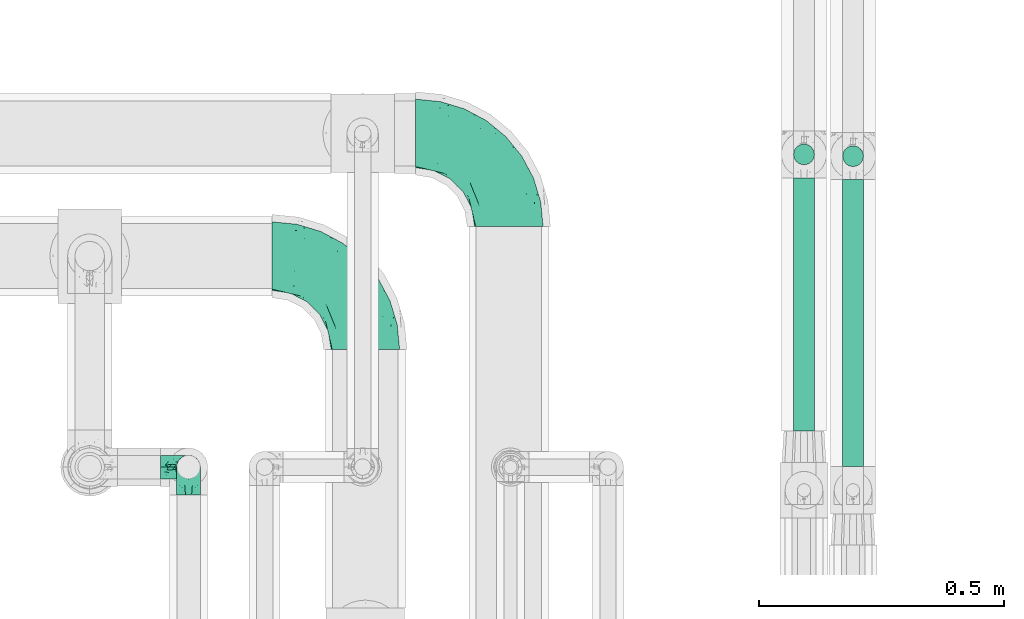
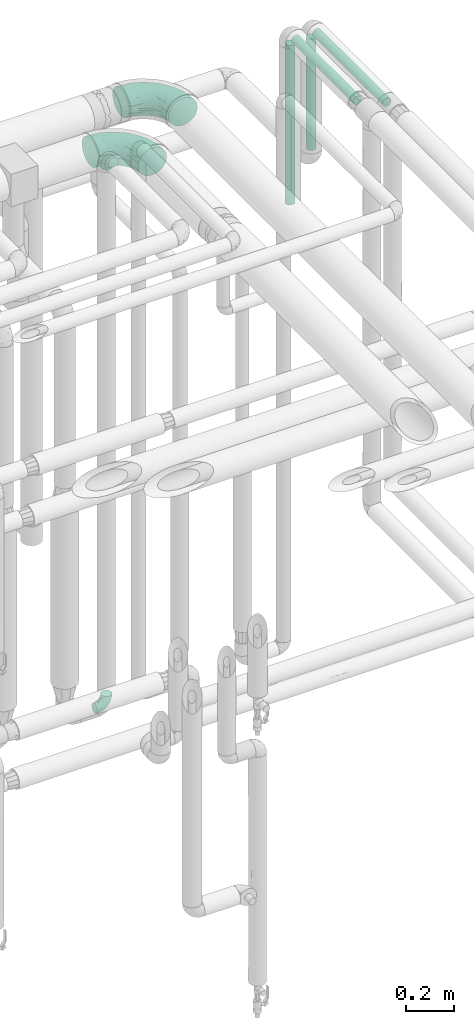
# One storey, part 726 of 827: 4 flow fittings, 4 flow segments.
"""IFC2X3 building model written with IfcOpenShell, lengths in millimetres."""

from ifc_helpers import new_model, entity, si_unit, converted_unit, derived_unit, direction, frame, origin, origin_2d_with_axis, place, context, subcontext, project, spatial, circle, extrude, faceted_brep, source, transform, mapped, material, type_object, type_shapes, element, save


model = new_model("IFC2X3")

# Units and contexts
model_context = context("Model", 3, precision=0.01, world=origin(), true_north=direction((6.12303176911189e-17, 1.0)))
body_context = subcontext(model_context, "Body", "Model", "MODEL_VIEW")
ifc_project = project(units=[si_unit("LENGTHUNIT", "METRE", prefix="MILLI"), si_unit("AREAUNIT", "SQUARE_METRE"), si_unit("VOLUMEUNIT", "CUBIC_METRE"), converted_unit("PLANEANGLEUNIT", "DEGREE", entity("IfcRatioMeasure", 0.0174532925199433), si_unit("PLANEANGLEUNIT", "RADIAN"), dimensions=[0, 0, 0, 0, 0, 0, 0]), si_unit("MASSUNIT", "GRAM", prefix="KILO"), derived_unit("MASSDENSITYUNIT", [(si_unit("MASSUNIT", "GRAM", prefix="KILO"), 1), (si_unit("LENGTHUNIT", "METRE"), -3)]), derived_unit("MOMENTOFINERTIAUNIT", [(si_unit("LENGTHUNIT", "METRE"), 4)]), si_unit("TIMEUNIT", "SECOND"), si_unit("FREQUENCYUNIT", "HERTZ"), si_unit("THERMODYNAMICTEMPERATUREUNIT", "DEGREE_CELSIUS"), derived_unit("THERMALTRANSMITTANCEUNIT", [(si_unit("MASSUNIT", "GRAM", prefix="KILO"), 1), (si_unit("THERMODYNAMICTEMPERATUREUNIT", "KELVIN"), -1), (si_unit("TIMEUNIT", "SECOND"), -3)]), derived_unit("VOLUMETRICFLOWRATEUNIT", [(si_unit("LENGTHUNIT", "METRE"), 3), (si_unit("TIMEUNIT", "SECOND"), -1)]), derived_unit("MASSFLOWRATEUNIT", [(si_unit("MASSUNIT", "GRAM", prefix="KILO"), 1), (si_unit("TIMEUNIT", "SECOND"), -1)]), derived_unit("ROTATIONALFREQUENCYUNIT", [(si_unit("TIMEUNIT", "SECOND"), -1)]), si_unit("ELECTRICCURRENTUNIT", "AMPERE"), si_unit("ELECTRICVOLTAGEUNIT", "VOLT"), si_unit("POWERUNIT", "WATT"), si_unit("FORCEUNIT", "NEWTON", prefix="KILO"), si_unit("ILLUMINANCEUNIT", "LUX"), si_unit("LUMINOUSFLUXUNIT", "LUMEN"), si_unit("LUMINOUSINTENSITYUNIT", "CANDELA"), derived_unit("USERDEFINED", [(si_unit("MASSUNIT", "GRAM", prefix="KILO"), -1), (si_unit("LENGTHUNIT", "METRE"), -2), (si_unit("TIMEUNIT", "SECOND"), 3), (si_unit("LUMINOUSFLUXUNIT", "LUMEN"), 1)]), derived_unit("LINEARVELOCITYUNIT", [(si_unit("LENGTHUNIT", "METRE"), 1), (si_unit("TIMEUNIT", "SECOND"), -1)]), si_unit("PRESSUREUNIT", "PASCAL"), derived_unit("USERDEFINED", [(si_unit("LENGTHUNIT", "METRE"), -2), (si_unit("MASSUNIT", "GRAM", prefix="KILO"), 1), (si_unit("TIMEUNIT", "SECOND"), -2)]), derived_unit("LINEARFORCEUNIT", [(si_unit("MASSUNIT", "GRAM", prefix="KILO"), 1), (si_unit("LENGTHUNIT", "METRE"), 1), (si_unit("TIMEUNIT", "SECOND"), -2), (si_unit("LENGTHUNIT", "METRE"), -1)]), derived_unit("PLANARFORCEUNIT", [(si_unit("MASSUNIT", "GRAM", prefix="KILO"), 1), (si_unit("LENGTHUNIT", "METRE"), 1), (si_unit("TIMEUNIT", "SECOND"), -2), (si_unit("LENGTHUNIT", "METRE"), -2)])], contexts=[model_context])

# Site, building, storey
site_placement = place(None, origin())
site = spatial("IfcSite", under=ifc_project, at=site_placement, CompositionType="ELEMENT")
building_placement = place(site_placement, origin())
building = spatial("IfcBuilding", under=site, at=building_placement, CompositionType="ELEMENT")
storey_placement = place(building_placement, frame((0.0, 0.0, 28200.0)))
storey = spatial("IfcBuildingStorey", under=building, at=storey_placement, Name="08", CompositionType="ELEMENT", Elevation=28200.0)

# Flow segments
pipe_segment_type = type_object("IfcPipeSegmentType", PredefinedType="NOTDEFINED")
flow_segment_1_placement = place(storey_placement, frame((61129.89, 17500.83, 2977.0)))
element("IfcFlowSegment", 1, at=flow_segment_1_placement, inside=storey, type_object=pipe_segment_type, context=body_context, shape_type="SweptSolid", body=[
    extrude(circle(Radius=21.15, at=origin_2d_with_axis()), frame((22.75, 0.0, 22.75), z_axis=(0.0, 1.0, 0.0), x_axis=(1.0, 0.0, 0.0)), (0.0, 0.0, 1.0), 585.000000000008),
])
flow_segment_2_placement = place(storey_placement, frame((61029.89, 17573.83, 2977.0)))
element("IfcFlowSegment", 2, at=flow_segment_2_placement, inside=storey, type_object=pipe_segment_type, context=body_context, shape_type="SweptSolid", body=[
    extrude(circle(Radius=21.15, at=origin_2d_with_axis()), frame((22.75, 0.0, 22.75), z_axis=(0.0, 1.0, 0.0), x_axis=(1.0, 0.0, 0.0)), (0.0, 0.0, 1.0), 515.500000000028),
])
flow_segment_3_placement = place(storey_placement, frame((61029.89, 18114.59, 2137.37)))
element("IfcFlowSegment", 3, at=flow_segment_3_placement, inside=storey, type_object=pipe_segment_type, context=body_context, shape_type="SweptSolid", body=[
    extrude(circle(Radius=21.15, at=origin_2d_with_axis()), frame((22.75, 22.75, 0.0)), (0.0, 0.0, 1.0), 814.370023810611),
])
flow_segment_4_placement = place(storey_placement, frame((61129.89, 18111.09, 2382.74)))
element("IfcFlowSegment", 4, at=flow_segment_4_placement, inside=storey, type_object=pipe_segment_type, context=body_context, shape_type="SweptSolid", body=[
    extrude(circle(Radius=21.15, at=origin_2d_with_axis()), frame((22.75, 22.75, 0.0)), (0.0, 0.0, 1.0), 569.000000000031),
])

# Flow fittings
ifc_material = material()
pipe_fitting_type_1 = type_object("IfcPipeFittingType", Name="ADSK_1", PredefinedType="NOTDEFINED", material=ifc_material)
shared_shape_1 = source(origin(), body_context, "Body", "Brep", [
    faceted_brep([(-57.0, 12.07, -20.91), (-57.0, 6.25, -23.33), (-57.0, 0.0, -24.15), (-57.0, -6.25, -23.33), (-57.0, -12.08, -20.91), (-57.0, -17.08, -17.08), (-57.0, -20.91, -12.08), (-57.0, -23.33, -6.25), (-57.0, -24.15, 0.0), (-57.0, -23.33, 6.25), (-57.0, -20.91, 12.07), (-57.0, -17.08, 17.08), (-57.0, -12.08, 20.91), (-57.0, -6.25, 23.33), (-57.0, 0.0, 24.15), (-57.0, 6.25, 23.33), (-57.0, 12.07, 20.91), (-57.0, 17.08, 17.08), (-57.0, 20.91, 12.07), (-57.0, 23.33, 6.25), (-57.0, 24.15, 0.0), (-57.0, 23.33, -6.25), (-57.0, 20.91, -12.08), (-57.0, 17.08, -17.08), (0.0, 57.0, -24.15), (-6.25, 57.0, -23.33), (-12.07, 57.0, -20.91), (-17.08, 57.0, -17.08), (-20.91, 57.0, -12.08), (-23.33, 57.0, -6.25), (-24.15, 57.0, 0.0), (-23.33, 57.0, 6.25), (-20.91, 57.0, 12.07), (-17.08, 57.0, 17.08), (-12.07, 57.0, 20.91), (-6.25, 57.0, 23.33), (0.0, 57.0, 24.15), (6.25, 57.0, 23.33), (12.08, 57.0, 20.91), (17.08, 57.0, 17.08), (20.91, 57.0, 12.07), (23.33, 57.0, 6.25), (24.15, 57.0, 0.0), (23.33, 57.0, -6.25), (20.91, 57.0, -12.08), (17.08, 57.0, -17.08), (12.08, 57.0, -20.91), (6.25, 57.0, -23.33), (14.9, 21.14, 6.17), (13.61, 24.64, 12.48), (6.23, 8.95, 8.98), (-41.47, -21.06, 0.0), (-41.92, -18.38, 13.72), (-24.64, -13.61, 12.48), (-37.37, -13.24, 18.15), (-6.8, -4.93, 8.18), (-21.76, -15.19, 6.22), (-12.78, -9.18, 0.0), (-37.73, -20.51, 7.75), (-7.38, 7.38, 20.24), (-23.37, -4.26, 20.42), (-11.9, -3.19, 15.86), (-42.14, -8.7, 21.82), (13.24, 37.37, 18.15), (9.33, 23.53, 16.85), (4.26, 23.37, 20.42), (2.77, 10.92, 15.55), (-29.46, 0.91, 23.52), (-44.13, 20.56, 15.69), (-39.25, 26.33, 10.88), (-49.02, 22.92, 9.96), (-34.58, 23.87, 17.15), (-15.8, 6.8, 22.81), (-8.67, 20.47, 23.88), (-18.12, 12.9, 24.08), (-48.29, 14.92, 19.65), (-44.06, -2.85, 23.78), (-9.23, 48.95, 22.58), (-3.78, 42.74, 24.07), (-40.34, 4.26, 24.09), (-44.02, 26.14, 5.46), (-44.04, 9.88, 22.74), (-4.95, 16.87, 22.52), (-2.75, 1.43, 12.5), (-25.48, 40.98, 10.71), (20.51, 37.73, 7.75), (18.38, 41.92, 13.72), (8.7, 42.14, 21.82), (-25.95, -17.97, 0.0), (2.85, 44.06, 23.78), (21.06, 41.47, 0.0), (17.97, 25.95, 0.0), (-24.04, -9.27, 17.13), (-33.26, 33.26, 5.86), (-28.55, 40.57, 0.0), (-40.57, 28.55, 0.0), (-25.29, 47.19, 4.06), (-27.01, 31.1, 16.77), (-15.7, 43.95, 19.9), (-20.27, 45.22, 15.61), (-30.53, 31.98, 12.64), (-11.28, 38.33, 22.92), (-9.97, 27.88, 24.09), (-20.15, 30.26, 21.25), (-31.25, 11.75, 23.64), (-28.75, 7.23, 24.15), (-29.53, 18.06, 22.27), (-28.44, 24.21, 20.02), (-37.55, 17.7, 20.26), (-15.88, 29.25, 22.99), (-20.82, 20.82, 23.44), (-0.91, 29.46, 23.52), (-13.5, -7.67, 12.04), (1.49, 1.56, 5.16), (8.86, 10.35, 4.59), (0.38, -0.38, 0.0), (9.18, 12.78, 0.0), (-37.37, -13.24, -18.15), (8.86, 10.35, -4.59), (-45.22, 20.27, -15.61), (-43.95, 15.7, -19.9), (-38.33, 11.28, -22.92), (-48.95, 9.23, -22.58), (-47.19, 25.29, -4.06), (-33.26, 33.26, -5.86), (18.38, 41.92, -13.72), (-30.26, 20.15, -21.25), (2.85, 44.06, -23.78), (-4.26, 40.34, -24.09), (-40.98, 25.48, -10.71), (-41.92, -18.38, -13.72), (9.25, 23.5, -16.92), (4.26, 23.37, -20.42), (13.24, 37.37, -18.15), (-37.73, -20.51, -7.75), (-11.75, 31.25, -23.64), (-7.23, 28.75, -24.15), (-12.9, 18.12, -24.08), (8.7, 42.14, -21.82), (-44.06, -2.85, -23.78), (-6.8, 15.8, -22.81), (-20.47, 8.67, -23.88), (-24.64, -13.61, -12.48), (-42.74, 3.78, -24.07), (-18.06, 29.53, -22.27), (-24.21, 28.44, -20.02), (-27.88, 9.97, -24.09), (-31.1, 27.01, -16.77), (-26.14, 44.02, -5.46), (14.9, 21.14, -6.17), (20.51, 37.73, -7.75), (-9.88, 44.04, -22.74), (-20.56, 44.13, -15.69), (-21.76, -15.19, -6.22), (-13.5, -7.67, -12.04), (-24.14, -9.76, -16.74), (-11.9, -3.19, -15.86), (-14.92, 48.29, -19.65), (-23.37, -4.26, -20.42), (-0.91, 29.46, -23.52), (-26.33, 39.25, -10.88), (-23.87, 34.58, -17.15), (-42.14, -8.7, -21.82), (-22.92, 49.02, -9.96), (13.61, 24.64, -12.48), (-31.98, 30.53, -12.64), (-16.87, 4.95, -22.52), (-17.7, 37.55, -20.26), (-29.25, 15.88, -22.99), (-20.82, 20.82, -23.44), (-29.46, 0.91, -23.52), (-7.38, 7.38, -20.24), (2.77, 10.92, -15.55), (6.23, 8.95, -8.98), (-6.8, -4.93, -8.18), (-2.81, 1.41, -12.54), (1.49, 1.56, -5.16)], [[[0, 1, 2, 3, 4, 5, 6, 7, 8, 9, 10, 11, 12, 13, 14, 15, 16, 17, 18, 19, 20, 21, 22, 23]], [[24, 25, 26, 27, 28, 29, 30, 31, 32, 33, 34, 35, 36, 37, 38, 39, 40, 41, 42, 43, 44, 45, 46, 47]], [[48, 49, 50]], [[9, 8, 51]], [[52, 53, 54]], [[55, 56, 57]], [[10, 58, 52]], [[9, 58, 10]], [[59, 60, 61]], [[54, 12, 11]], [[54, 62, 12]], [[63, 39, 38]], [[64, 65, 66]], [[62, 60, 67]], [[68, 69, 70]], [[71, 69, 68]], [[72, 73, 74]], [[16, 75, 17]], [[13, 76, 14]], [[35, 77, 78]], [[14, 79, 15]], [[17, 68, 18]], [[14, 76, 79]], [[20, 19, 80]], [[70, 19, 18]], [[81, 15, 79]], [[15, 81, 16]], [[73, 72, 82]], [[66, 83, 50]], [[32, 31, 84]], [[85, 86, 49]], [[63, 87, 65]], [[56, 58, 88]], [[36, 89, 37]], [[85, 41, 40]], [[36, 35, 78]], [[90, 41, 85]], [[40, 39, 86]], [[12, 62, 13]], [[86, 85, 40]], [[48, 85, 49]], [[85, 91, 90]], [[87, 38, 37]], [[92, 60, 54]], [[80, 69, 93]], [[93, 94, 95]], [[10, 52, 11]], [[94, 96, 30]], [[97, 98, 99]], [[80, 93, 95]], [[100, 97, 84]], [[99, 98, 33]], [[101, 102, 78]], [[103, 101, 98]], [[96, 31, 30]], [[77, 98, 101]], [[77, 35, 34]], [[34, 33, 98]], [[9, 51, 58]], [[87, 63, 38]], [[104, 105, 74]], [[106, 103, 107]], [[106, 81, 104]], [[75, 68, 17]], [[108, 107, 71]], [[33, 32, 99]], [[109, 103, 110]], [[101, 109, 102]], [[89, 78, 111]], [[53, 52, 58]], [[54, 11, 52]], [[60, 62, 54]], [[88, 58, 51]], [[76, 62, 67]], [[53, 112, 92]], [[60, 59, 72]], [[39, 63, 86]], [[49, 86, 63]], [[89, 87, 37]], [[42, 41, 90]], [[111, 82, 65]], [[111, 65, 87]], [[65, 59, 66]], [[104, 81, 79]], [[75, 81, 108]], [[32, 84, 99]], [[97, 99, 84]], [[98, 97, 103]], [[106, 107, 108]], [[74, 102, 110]], [[111, 78, 102]], [[74, 110, 104]], [[74, 67, 72]], [[61, 92, 112]], [[66, 59, 61]], [[56, 53, 58]], [[66, 50, 49]], [[61, 112, 83]], [[66, 49, 64]], [[78, 89, 36]], [[87, 89, 111]], [[62, 76, 13]], [[79, 76, 67]], [[100, 93, 69]], [[96, 93, 84]], [[55, 113, 50]], [[113, 114, 50]], [[104, 79, 105]], [[106, 104, 110]], [[20, 80, 95]], [[85, 48, 91]], [[115, 114, 113]], [[116, 91, 48]], [[70, 80, 19]], [[93, 96, 94]], [[84, 31, 96]], [[103, 106, 110]], [[81, 106, 108]], [[103, 97, 107]], [[71, 107, 97]], [[71, 97, 100]], [[108, 71, 68]], [[79, 67, 105]], [[67, 74, 105]], [[115, 113, 57]], [[112, 56, 55]], [[56, 88, 57]], [[60, 72, 67]], [[82, 72, 59]], [[65, 82, 59]], [[82, 111, 73]], [[111, 102, 73]], [[102, 74, 73]], [[81, 75, 16]], [[68, 75, 108]], [[68, 70, 18]], [[80, 70, 69]], [[98, 77, 34]], [[78, 77, 101]], [[93, 100, 84]], [[71, 100, 69]], [[102, 109, 110]], [[101, 103, 109]], [[53, 92, 54]], [[61, 60, 92]], [[56, 112, 53]], [[83, 112, 55]], [[50, 83, 55]], [[61, 83, 66]], [[49, 63, 64]], [[65, 64, 63]], [[57, 113, 55]], [[114, 115, 116]], [[116, 48, 114]], [[48, 50, 114]], [[117, 5, 4]], [[116, 115, 118]], [[119, 120, 23]], [[121, 122, 120]], [[95, 123, 20]], [[0, 23, 120]], [[124, 95, 94]], [[125, 45, 44]], [[121, 120, 126]], [[24, 127, 128]], [[22, 21, 129]], [[0, 122, 1]], [[5, 117, 130]], [[131, 132, 133]], [[134, 88, 51]], [[135, 136, 137]], [[6, 5, 130]], [[46, 138, 47]], [[139, 3, 2]], [[140, 141, 137]], [[6, 134, 7]], [[134, 130, 142]], [[143, 2, 1]], [[144, 126, 145]], [[121, 146, 143]], [[147, 120, 119]], [[94, 148, 124]], [[149, 150, 91]], [[30, 29, 148]], [[151, 25, 128]], [[27, 152, 28]], [[134, 153, 88]], [[154, 155, 156]], [[27, 26, 157]], [[151, 26, 25]], [[155, 158, 156]], [[24, 47, 127]], [[1, 122, 143]], [[138, 132, 159]], [[160, 152, 161]], [[24, 128, 25]], [[46, 133, 138]], [[162, 117, 4]], [[148, 160, 124]], [[152, 160, 163]], [[154, 142, 155]], [[45, 125, 133]], [[133, 46, 45]], [[125, 164, 133]], [[51, 7, 134]], [[42, 90, 43]], [[165, 147, 129]], [[153, 134, 142]], [[43, 150, 44]], [[162, 4, 3]], [[141, 140, 166]], [[117, 162, 158]], [[163, 29, 28]], [[43, 90, 150]], [[123, 21, 20]], [[144, 151, 135]], [[157, 152, 27]], [[167, 145, 161]], [[23, 22, 119]], [[168, 126, 169]], [[121, 168, 146]], [[139, 143, 170]], [[142, 130, 117]], [[8, 7, 51]], [[134, 6, 130]], [[139, 162, 3]], [[170, 166, 158]], [[170, 158, 162]], [[158, 171, 156]], [[44, 150, 125]], [[91, 150, 90]], [[164, 125, 150]], [[132, 138, 133]], [[127, 138, 159]], [[131, 164, 172]], [[132, 171, 140]], [[135, 151, 128]], [[157, 151, 167]], [[22, 129, 119]], [[147, 119, 129]], [[120, 147, 126]], [[144, 145, 167]], [[137, 146, 169]], [[170, 143, 146]], [[137, 169, 135]], [[137, 159, 140]], [[171, 172, 156]], [[173, 174, 175]], [[156, 175, 154]], [[174, 57, 153]], [[132, 172, 171]], [[172, 164, 173]], [[143, 139, 2]], [[162, 139, 170]], [[138, 127, 47]], [[128, 127, 159]], [[165, 124, 160]], [[123, 124, 129]], [[149, 173, 164]], [[176, 174, 173]], [[135, 128, 136]], [[144, 135, 169]], [[150, 149, 164]], [[176, 118, 115]], [[149, 91, 116]], [[30, 148, 94]], [[163, 148, 29]], [[124, 123, 95]], [[129, 21, 123]], [[126, 144, 169]], [[151, 144, 167]], [[126, 147, 145]], [[161, 145, 147]], [[161, 147, 165]], [[167, 161, 152]], [[128, 159, 136]], [[159, 137, 136]], [[154, 153, 142]], [[132, 140, 159]], [[174, 176, 57]], [[57, 88, 153]], [[166, 140, 171]], [[158, 166, 171]], [[166, 170, 141]], [[170, 146, 141]], [[146, 137, 141]], [[151, 157, 26]], [[152, 157, 167]], [[152, 163, 28]], [[148, 163, 160]], [[120, 122, 0]], [[143, 122, 121]], [[124, 165, 129]], [[161, 165, 160]], [[146, 168, 169]], [[121, 126, 168]], [[142, 117, 155]], [[158, 155, 117]], [[175, 156, 172]], [[153, 154, 174]], [[173, 175, 172]], [[174, 154, 175]], [[164, 131, 133]], [[172, 132, 131]], [[176, 173, 118]], [[57, 176, 115]], [[173, 149, 118]], [[149, 116, 118]]]),
])
type_shapes(pipe_fitting_type_1, [shared_shape_1])
for number, where, z_axis, x_axis, name in (
    (5, (59798.13, 17500.0, 3200.0), (1.0, 0.0, 0.0), (0.0, 0.0, 1.0), "ADSK_1"),
    (6, (59798.13, 17500.0, 400.0), (0.0, 1.0, 0.0), (0.0, 0.0, -1.0), "ADSK_1"),
):
    element("IfcFlowFitting", number, at=place(storey_placement, frame(where, z_axis=z_axis, x_axis=x_axis)), inside=storey, type_object=pipe_fitting_type_1, material=ifc_material, Name=name, ObjectType="ADSK_1", context=body_context, shape_type="MappedRepresentation", body=[
        mapped(shared_shape_1, transform((0.0, 0.0, 0.0), scale=1.0)),
    ])
pipe_fitting_type_2 = type_object("IfcPipeFittingType", Name="ADSK_1", PredefinedType="NOTDEFINED", material=ifc_material)
shared_shape_2 = source(origin(), body_context, "Body", "Brep", [
    faceted_brep([(-190.0, 18.08, -67.47), (-190.0, 0.0, -69.85), (-190.0, -18.08, -67.47), (-190.0, -34.93, -60.49), (-190.0, -49.39, -49.39), (-190.0, -60.49, -34.93), (-190.0, -67.47, -18.08), (-190.0, -69.85, 0.0), (-190.0, -67.47, 18.08), (-190.0, -60.49, 34.92), (-190.0, -49.39, 49.39), (-190.0, -34.93, 60.49), (-190.0, -18.08, 67.47), (-190.0, 0.0, 69.85), (-190.0, 18.08, 67.47), (-190.0, 34.92, 60.49), (-190.0, 49.39, 49.39), (-190.0, 60.49, 34.92), (-190.0, 67.47, 18.08), (-190.0, 69.85, 0.0), (-190.0, 67.47, -18.08), (-190.0, 60.49, -34.93), (-190.0, 49.39, -49.39), (-190.0, 34.92, -60.49), (18.08, 190.0, -67.47), (0.0, 190.0, -69.85), (-18.08, 190.0, -67.47), (-34.92, 190.0, -60.49), (-49.39, 190.0, -49.39), (-60.49, 190.0, -34.93), (-67.47, 190.0, -18.08), (-69.85, 190.0, 0.0), (-67.47, 190.0, 18.08), (-60.49, 190.0, 34.92), (-49.39, 190.0, 49.39), (-34.92, 190.0, 60.49), (-18.08, 190.0, 67.47), (0.0, 190.0, 69.85), (18.08, 190.0, 67.47), (34.93, 190.0, 60.49), (49.39, 190.0, 49.39), (60.49, 190.0, 34.92), (67.47, 190.0, 18.08), (69.85, 190.0, 0.0), (67.47, 190.0, -18.08), (60.49, 190.0, -34.93), (49.39, 190.0, -49.39), (34.93, 190.0, -60.49), (-29.62, 146.98, 65.62), (-13.75, 135.37, 69.64), (-124.22, -36.33, 52.83), (-140.23, -52.18, 40.04), (-80.56, -34.09, 36.78), (-140.97, -24.01, 63.29), (-80.93, -8.05, 59.8), (-100.59, 5.62, 68.24), (-125.19, -57.65, 22.9), (-139.31, -64.86, 0.0), (-28.7, -8.91, 22.6), (-45.64, -26.06, 0.0), (-6.26, 6.26, 0.0), (-105.44, 36.89, 68.2), (-118.83, 43.56, 64.34), (-146.98, 29.62, 65.62), (-71.47, -38.86, 17.07), (-90.56, -50.07, 0.0), (-0.6, 27.02, 35.97), (-44.76, -2.31, 47.74), (-42.86, -12.1, 35.78), (-148.03, -7.38, 68.85), (-135.37, 13.75, 69.64), (-67.48, 159.11, 28.79), (36.32, 124.15, 52.82), (-38.8, 102.11, 68.2), (-24.59, 96.61, 69.85), (-81.73, 130.22, 21.92), (-65.15, 30.31, 68.68), (-27.72, 54.52, 66.49), (-44.98, 61.25, 69.74), (-75.73, 152.87, 0.0), (-159.11, 67.48, 28.79), (-130.22, 81.73, 21.92), (-152.87, 75.73, 0.0), (-76.65, 126.59, 35.57), (-101.51, 101.51, 25.92), (-96.74, 96.74, 38.75), (-144.94, 60.97, 45.11), (-159.57, 43.91, 56.71), (-119.38, 92.8, 0.0), (50.07, 90.56, 0.0), (57.42, 124.25, 22.84), (38.8, 71.6, 17.49), (64.86, 139.31, 0.0), (52.17, 140.21, 40.03), (33.37, 79.39, 36.99), (24.0, 140.95, 63.29), (8.03, 80.92, 59.81), (-82.61, -22.17, 50.94), (7.38, 148.03, 68.85), (-100.26, 79.14, 51.33), (-75.76, 96.1, 55.72), (-76.12, 111.95, 46.7), (-92.8, 119.38, 0.0), (-104.27, 104.27, 12.31), (10.07, 27.17, 16.15), (26.06, 45.64, 0.0), (-61.21, 144.14, 45.16), (-44.13, 158.15, 56.77), (-55.26, 120.41, 58.38), (9.95, 57.03, 48.64), (29.48, 90.08, 47.56), (-5.62, 100.59, 68.24), (-122.78, 54.24, 58.28), (-86.25, 73.26, 61.12), (-95.79, 24.47, 69.85), (-126.59, 76.65, 35.57), (-17.15, 26.56, 50.85), (-29.82, 29.82, 59.54), (-70.73, 11.02, 65.19), (-58.6, 94.58, 64.16), (-71.14, 66.1, 67.41), (-158.15, 44.13, -56.77), (33.37, 79.39, -36.99), (10.07, 27.17, -16.15), (-0.6, 27.02, -35.97), (-100.59, 5.62, -68.24), (-148.03, -7.38, -68.85), (-135.37, 13.75, -69.64), (-130.22, 81.73, -21.92), (-146.98, 29.62, -65.62), (-102.11, 38.8, -68.2), (-96.61, 24.59, -69.85), (-83.02, -24.86, -48.76), (-44.76, -2.31, -47.74), (-80.56, -34.09, -36.78), (-122.68, -57.24, -22.15), (-71.43, -38.87, -16.95), (-104.27, 104.27, -12.31), (-159.11, 67.48, -28.79), (-144.14, 61.21, -45.16), (7.38, 148.03, -68.85), (-13.75, 135.37, -69.64), (-79.14, 100.26, -51.33), (-96.1, 75.76, -55.72), (-111.95, 76.12, -46.7), (-80.93, -8.05, -59.8), (-124.22, -36.33, -52.83), (-140.23, -52.18, -40.04), (-24.47, 95.79, -69.85), (-36.89, 105.44, -68.2), (-150.18, -65.36, -13.92), (-43.56, 118.83, -64.34), (-29.62, 146.98, -65.62), (38.8, 71.6, -17.49), (-81.73, 130.22, -21.92), (-28.7, -8.91, -22.6), (-54.24, 122.78, -58.28), (-73.26, 86.25, -61.12), (-61.25, 44.98, -69.74), (-30.31, 65.15, -68.68), (-54.52, 27.72, -66.49), (-101.51, 101.51, -25.92), (-126.59, 76.65, -35.57), (-96.74, 96.74, -38.75), (-67.48, 159.11, -28.79), (-120.41, 55.26, -58.38), (-43.91, 159.57, -56.71), (24.0, 140.95, -63.29), (8.03, 80.92, -59.81), (-5.62, 100.59, -68.24), (-60.97, 144.94, -45.11), (36.32, 124.15, -52.82), (57.42, 124.25, -22.84), (52.17, 140.21, -40.03), (-140.97, -24.01, -63.29), (9.95, 57.03, -48.64), (-76.65, 126.59, -35.57), (22.84, 89.04, -52.94), (-11.03, 70.74, -65.2), (-29.82, 29.82, -59.54), (-94.58, 58.6, -64.16), (-66.1, 71.14, -67.41), (-31.42, -3.01, -36.09), (-13.88, 24.32, -46.86)], [[[0, 1, 2, 3, 4, 5, 6, 7, 8, 9, 10, 11, 12, 13, 14, 15, 16, 17, 18, 19, 20, 21, 22, 23]], [[24, 25, 26, 27, 28, 29, 30, 31, 32, 33, 34, 35, 36, 37, 38, 39, 40, 41, 42, 43, 44, 45, 46, 47]], [[36, 48, 49]], [[50, 51, 52]], [[53, 54, 55]], [[56, 9, 8]], [[8, 7, 57]], [[58, 59, 60]], [[51, 9, 56]], [[61, 62, 63]], [[59, 58, 64]], [[59, 64, 65]], [[11, 10, 50]], [[66, 67, 68]], [[50, 53, 11]], [[69, 70, 13]], [[71, 33, 32]], [[72, 40, 39]], [[73, 74, 49]], [[63, 15, 14]], [[13, 70, 14]], [[71, 32, 75]], [[12, 69, 13]], [[76, 77, 78]], [[32, 79, 75]], [[18, 80, 81]], [[63, 14, 70]], [[82, 19, 18]], [[83, 84, 85]], [[86, 16, 87]], [[82, 81, 88]], [[82, 18, 81]], [[15, 87, 16]], [[83, 71, 75]], [[52, 56, 64]], [[49, 37, 36]], [[89, 90, 91]], [[36, 35, 48]], [[42, 41, 90]], [[89, 92, 90]], [[11, 53, 12]], [[73, 78, 74]], [[65, 56, 57]], [[40, 72, 93]], [[94, 90, 93]], [[41, 40, 93]], [[72, 95, 96]], [[95, 39, 38]], [[8, 57, 56]], [[43, 42, 92]], [[67, 54, 97]], [[38, 37, 98]], [[99, 100, 101]], [[102, 75, 79]], [[51, 10, 9]], [[102, 88, 103]], [[31, 79, 32]], [[104, 60, 105]], [[106, 34, 33]], [[84, 103, 81]], [[91, 105, 89]], [[107, 35, 34]], [[106, 108, 107]], [[49, 48, 73]], [[104, 105, 91]], [[16, 86, 17]], [[58, 104, 66]], [[109, 110, 96]], [[111, 98, 49]], [[112, 113, 99]], [[92, 42, 90]], [[95, 72, 39]], [[70, 114, 61]], [[80, 18, 17]], [[101, 106, 83]], [[99, 86, 112]], [[115, 81, 80]], [[90, 94, 91]], [[94, 66, 104]], [[64, 58, 68]], [[56, 65, 64]], [[93, 72, 110]], [[90, 41, 93]], [[98, 95, 38]], [[111, 77, 96]], [[111, 96, 95]], [[67, 116, 117]], [[52, 51, 56]], [[50, 10, 51]], [[54, 53, 50]], [[69, 53, 55]], [[97, 52, 67]], [[118, 76, 55]], [[107, 48, 35]], [[73, 119, 120]], [[61, 63, 70]], [[63, 62, 87]], [[94, 104, 91]], [[58, 60, 104]], [[109, 66, 94]], [[67, 117, 54]], [[68, 67, 52]], [[116, 66, 109]], [[119, 48, 108]], [[73, 120, 78]], [[120, 61, 114]], [[78, 114, 76]], [[49, 98, 37]], [[95, 98, 111]], [[53, 69, 12]], [[70, 69, 55]], [[70, 55, 114]], [[120, 113, 62]], [[76, 114, 55]], [[120, 114, 78]], [[118, 55, 54]], [[76, 118, 77]], [[96, 77, 117]], [[111, 78, 77]], [[54, 117, 118]], [[77, 118, 117]], [[110, 109, 94]], [[116, 96, 117]], [[106, 107, 34]], [[48, 107, 108]], [[75, 84, 83]], [[106, 33, 71]], [[101, 83, 85]], [[106, 71, 83]], [[99, 101, 85]], [[108, 106, 101]], [[99, 85, 115]], [[113, 112, 62]], [[119, 113, 120]], [[100, 99, 113]], [[17, 86, 80]], [[115, 85, 84]], [[80, 86, 115]], [[99, 115, 86]], [[63, 87, 15]], [[86, 87, 112]], [[78, 111, 74]], [[111, 49, 74]], [[119, 100, 113]], [[101, 100, 108]], [[48, 119, 73]], [[119, 108, 100]], [[75, 102, 103]], [[115, 84, 81]], [[81, 103, 88]], [[75, 103, 84]], [[54, 50, 97]], [[52, 97, 50]], [[64, 68, 52]], [[66, 68, 58]], [[62, 61, 120]], [[87, 62, 112]], [[93, 110, 94]], [[96, 110, 72]], [[66, 116, 67]], [[96, 116, 109]], [[22, 121, 23]], [[122, 123, 124]], [[125, 126, 127]], [[20, 82, 128]], [[129, 130, 127]], [[130, 131, 127]], [[19, 82, 20]], [[132, 133, 134]], [[88, 128, 82]], [[135, 136, 65]], [[102, 137, 88]], [[138, 20, 128]], [[139, 22, 21]], [[140, 141, 25]], [[142, 143, 144]], [[145, 133, 132]], [[4, 146, 147]], [[141, 148, 149]], [[7, 6, 150]], [[138, 21, 20]], [[5, 4, 147]], [[149, 151, 152]], [[59, 65, 136]], [[122, 153, 123]], [[79, 30, 154]], [[134, 155, 136]], [[150, 65, 57]], [[156, 157, 142]], [[126, 2, 1]], [[134, 135, 147]], [[130, 158, 131]], [[159, 160, 158]], [[154, 161, 137]], [[0, 23, 129]], [[127, 1, 0]], [[162, 138, 128]], [[161, 163, 162]], [[30, 79, 31]], [[146, 4, 3]], [[154, 30, 164]], [[152, 27, 26]], [[165, 121, 139]], [[25, 24, 140]], [[25, 141, 26]], [[164, 30, 29]], [[27, 166, 28]], [[167, 168, 169]], [[141, 152, 26]], [[28, 170, 29]], [[47, 171, 167]], [[172, 89, 153]], [[59, 155, 60]], [[28, 166, 170]], [[46, 45, 173]], [[153, 89, 105]], [[105, 123, 153]], [[174, 146, 3]], [[171, 47, 46]], [[45, 44, 172]], [[7, 150, 57]], [[43, 92, 44]], [[122, 124, 175]], [[89, 172, 92]], [[171, 173, 122]], [[47, 167, 24]], [[173, 171, 46]], [[135, 150, 5]], [[0, 129, 127]], [[174, 3, 2]], [[79, 154, 102]], [[146, 174, 145]], [[44, 92, 172]], [[144, 139, 162]], [[142, 170, 156]], [[176, 154, 164]], [[105, 60, 123]], [[122, 172, 153]], [[45, 172, 173]], [[122, 173, 172]], [[167, 171, 177]], [[140, 167, 169]], [[177, 122, 175]], [[178, 159, 169]], [[134, 136, 135]], [[155, 59, 136]], [[134, 147, 146]], [[135, 5, 147]], [[126, 174, 2]], [[125, 160, 145]], [[125, 145, 174]], [[145, 179, 133]], [[121, 129, 23]], [[130, 180, 181]], [[149, 152, 141]], [[152, 151, 166]], [[60, 155, 123]], [[123, 155, 124]], [[182, 134, 133]], [[175, 179, 168]], [[183, 179, 175]], [[155, 182, 124]], [[180, 129, 165]], [[130, 181, 158]], [[181, 149, 148]], [[158, 148, 159]], [[127, 126, 1]], [[174, 126, 125]], [[167, 140, 24]], [[141, 140, 169]], [[141, 169, 148]], [[181, 157, 151]], [[159, 148, 169]], [[181, 148, 158]], [[178, 169, 168]], [[159, 178, 160]], [[145, 160, 179]], [[125, 158, 160]], [[168, 179, 178]], [[160, 178, 179]], [[175, 124, 183]], [[177, 175, 168]], [[139, 121, 22]], [[129, 121, 165]], [[128, 161, 162]], [[139, 21, 138]], [[144, 162, 163]], [[139, 138, 162]], [[142, 144, 163]], [[165, 139, 144]], [[142, 163, 176]], [[157, 156, 151]], [[180, 157, 181]], [[143, 142, 157]], [[29, 170, 164]], [[176, 163, 161]], [[164, 170, 176]], [[142, 176, 170]], [[152, 166, 27]], [[170, 166, 156]], [[158, 125, 131]], [[125, 127, 131]], [[180, 143, 157]], [[144, 143, 165]], [[129, 180, 130]], [[180, 165, 143]], [[128, 88, 137]], [[176, 161, 154]], [[154, 137, 102]], [[128, 137, 161]], [[5, 150, 6]], [[65, 150, 135]], [[134, 146, 132]], [[145, 132, 146]], [[134, 182, 155]], [[183, 182, 133]], [[151, 149, 181]], [[166, 151, 156]], [[182, 183, 124]], [[179, 183, 133]], [[167, 177, 168]], [[122, 177, 171]]]),
])
type_shapes(pipe_fitting_type_2, [shared_shape_2])
for number, where, z_axis, x_axis, name in (
    (7, (60451.05, 18180.1, 2900.0), (0.0, 0.0, 1.0), (0.0, 1.0, 0.0), "ADSK_1"),
    (8, (60158.54, 17930.1, 2899.96), (0.0, 0.0, 1.0), (0.0, 1.0, 0.0), "ADSK_1"),
):
    element("IfcFlowFitting", number, at=place(storey_placement, frame(where, z_axis=z_axis, x_axis=x_axis)), inside=storey, type_object=pipe_fitting_type_2, material=ifc_material, Name=name, ObjectType="ADSK_1", context=body_context, shape_type="MappedRepresentation", body=[
        mapped(shared_shape_2, transform((0.0, 0.0, 0.0), scale=1.0)),
    ])

save(model, "model.ifc")
